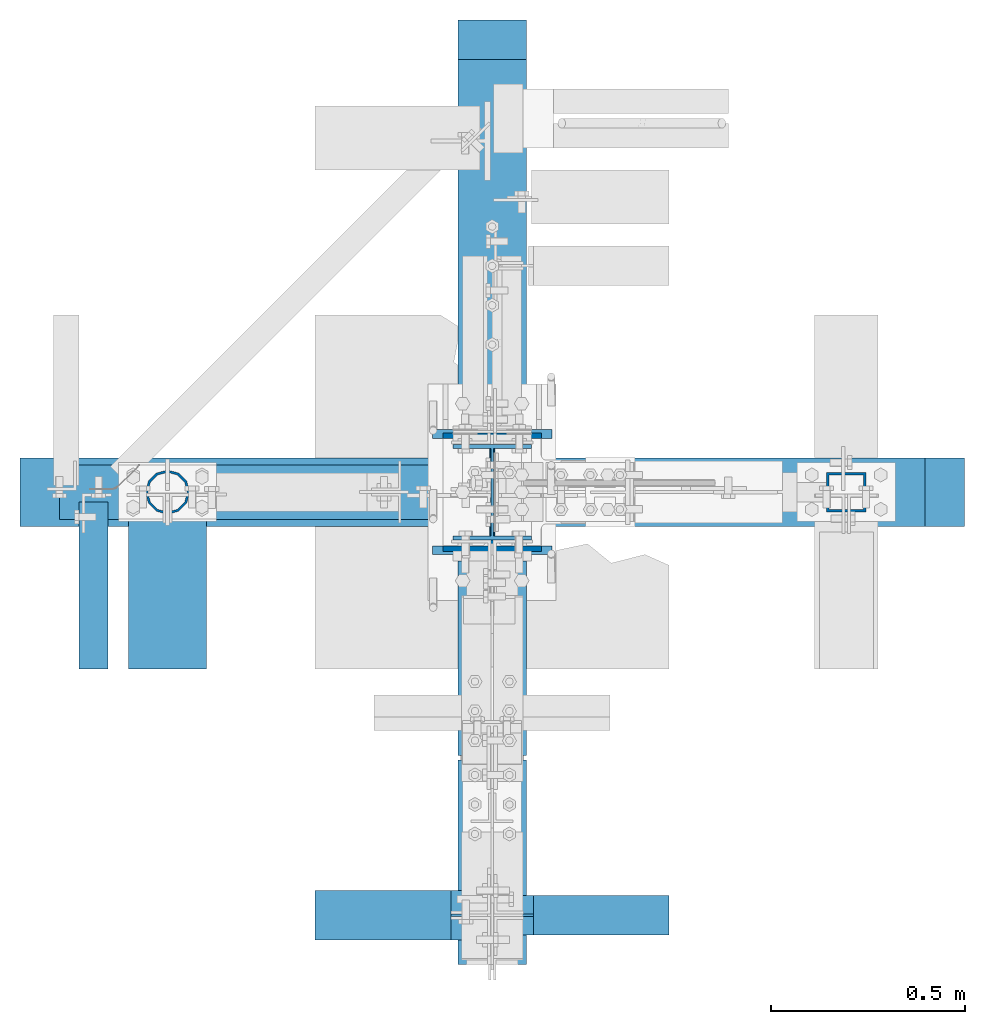
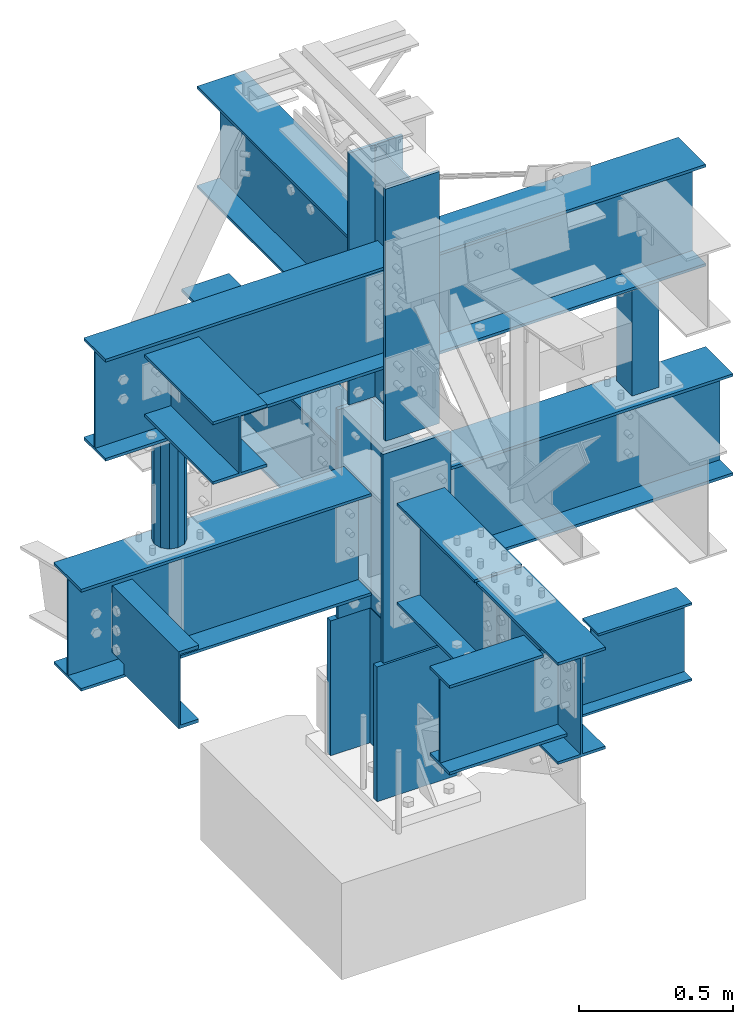
# Not in any storey, part 7 of 8: 12 beams, 5 columns, 17 elements without a shape of their own.
"""IFC2X3 building model written with IfcOpenShell, lengths in inches."""

from ifc_helpers import new_model, entity, si_unit, converted_unit, frame, origin_with_axes, place, context, project, spatial, faceted_brep, source, transform, mapped, material, type_object, type_shapes, element, aggregate, save


model = new_model("IFC2X3")

# Units and contexts
model_context = context("Model", 3, precision=1e-05, world=origin_with_axes())
ifc_project = project(units=[converted_unit("LENGTHUNIT", "INCH", entity("IfcLengthMeasure", 25.4), si_unit("LENGTHUNIT", "METRE", prefix="MILLI"), dimensions=[1, 0, 0, 0, 0, 0, 0]), si_unit("PLANEANGLEUNIT", "RADIAN"), si_unit("MASSUNIT", "GRAM", prefix="KILO"), si_unit("TIMEUNIT", "SECOND"), si_unit("AREAUNIT", "SQUARE_METRE"), si_unit("PRESSUREUNIT", "PASCAL"), si_unit("FORCEUNIT", "NEWTON"), si_unit("THERMODYNAMICTEMPERATUREUNIT", "DEGREE_CELSIUS")], contexts=[model_context])

# Site, building
site_placement = place(None, origin_with_axes())
site = spatial("IfcSite", under=ifc_project, at=site_placement, CompositionType="ELEMENT")
building_placement = place(site_placement, origin_with_axes())
building = spatial("IfcBuilding", under=site, at=building_placement, Name="Building", CompositionType="ELEMENT")

# Assembly, column
assembly_1_placement = place(building_placement, frame((0.0, 0.0, -1.5), z_axis=(0.0, -1.0, 0.0), x_axis=(0.0, 0.0, 1.0)))
assembly_1 = element("IfcElementAssembly", 1, at=assembly_1_placement, inside=building, Name="1-1", PredefinedType="NOTDEFINED")
ifc_material_1 = material()
column_type_1 = type_object("IfcColumnType", Name="W12x96", PredefinedType="COLUMN", material=ifc_material_1)
shared_shape_1 = source(origin_with_axes(), model_context, "Body", "Brep", [
    faceted_brep([(0.0, -6.08, -6.355), (0.0, -6.08, -5.455), (0.0, -0.275, -5.455), (0.0, -0.275, 5.455), (0.0, -6.08, 5.455), (0.0, -6.08, 6.355), (0.0, 6.08, 6.355), (0.0, 6.08, 5.455), (0.0, 0.275, 5.455), (0.0, 0.275, -5.455), (0.0, 6.08, -5.455), (0.0, 6.08, -6.355), (21.0, 6.08, -6.355), (21.0, 6.08, -5.455), (21.0, 0.275, -5.455), (21.0, 0.275, 5.455), (21.0, 6.08, 5.455), (21.0, 6.08, 6.355), (21.0, -6.08, 6.355), (21.0, -6.08, 5.455), (21.0, -0.275, 5.455), (21.0, -0.275, -5.455), (21.0, -6.08, -5.455), (21.0, -6.08, -6.355)], [[[0, 1, 2, 3, 4, 5, 6, 7, 8, 9, 10, 11]], [[12, 13, 14, 15, 16, 17, 18, 19, 20, 21, 22, 23]], [[0, 23, 22, 1]], [[1, 22, 21, 2]], [[2, 21, 20, 3]], [[3, 20, 19, 4]], [[4, 19, 18, 5]], [[5, 18, 17, 6]], [[6, 17, 16, 7]], [[7, 16, 15, 8]], [[8, 15, 14, 9]], [[9, 14, 13, 10]], [[10, 13, 12, 11]], [[11, 12, 23, 0]]]),
])
type_shapes(column_type_1, [shared_shape_1])
column_1_placement = place(assembly_1_placement, frame((1.5, 0.0, 0.0), z_axis=(0.0, 0.0, 1.0), x_axis=(1.0, 0.0, 0.0)))
column_1 = element("IfcColumn", 2, at=column_1_placement, type_object=column_type_1, Name="w1", ObjectType="Column", context=model_context, shape_type="MappedRepresentation", body=[
    mapped(shared_shape_1, transform((0.0, 0.0, 0.0), scale=1.0)),
])
aggregate(assembly_1, [column_1])

assembly_2_placement = place(building_placement, frame((0.0, 0.0, 21.0), z_axis=(0.0, -1.0, 0.0), x_axis=(0.0, 0.0, 1.0)))
assembly_2 = element("IfcElementAssembly", 3, at=assembly_2_placement, inside=building, Name="1-2", PredefinedType="NOTDEFINED")
column_type_2 = type_object("IfcColumnType", Name="W12x53", PredefinedType="COLUMN", material=ifc_material_1)
shared_shape_2 = source(origin_with_axes(), model_context, "Body", "Brep", [
    faceted_brep([(0.0, -4.997, -6.03), (0.0, -4.997, -5.455), (0.0, -0.172, -5.455), (0.0, -0.172, 5.455), (0.0, -4.997, 5.455), (0.0, -4.997, 6.03), (0.0, 4.997, 6.03), (0.0, 4.997, 5.455), (0.0, 0.172, 5.455), (0.0, 0.172, -5.455), (0.0, 4.997, -5.455), (0.0, 4.997, -6.03), (32.5, 4.997, -6.03), (32.5, 4.997, -5.455), (32.5, 0.172, -5.455), (32.5, 0.172, 5.455), (32.5, 4.997, 5.455), (32.5, 4.997, 6.03), (32.5, -4.997, 6.03), (32.5, -4.997, 5.455), (32.5, -0.172, 5.455), (32.5, -0.172, -5.455), (32.5, -4.997, -5.455), (32.5, -4.997, -6.03)], [[[0, 1, 2, 3, 4, 5, 6, 7, 8, 9, 10, 11]], [[12, 13, 14, 15, 16, 17, 18, 19, 20, 21, 22, 23]], [[0, 23, 22, 1]], [[1, 22, 21, 2]], [[2, 21, 20, 3]], [[3, 20, 19, 4]], [[4, 19, 18, 5]], [[5, 18, 17, 6]], [[6, 17, 16, 7]], [[7, 16, 15, 8]], [[8, 15, 14, 9]], [[9, 14, 13, 10]], [[10, 13, 12, 11]], [[11, 12, 23, 0]]]),
])
type_shapes(column_type_2, [shared_shape_2])
column_2_placement = place(assembly_2_placement, origin_with_axes())
column_2 = element("IfcColumn", 4, at=column_2_placement, type_object=column_type_2, Name="w10", ObjectType="Column", context=model_context, shape_type="MappedRepresentation", body=[
    mapped(shared_shape_2, transform((0.0, 0.0, 0.0), scale=1.0)),
])
aggregate(assembly_2, [column_2])

assembly_3_placement = place(building_placement, frame((0.0, 0.0, 54.5), z_axis=(0.0, -1.0, 0.0), x_axis=(0.0, 0.0, 1.0)))
assembly_3 = element("IfcElementAssembly", 5, at=assembly_3_placement, inside=building, Name="1-3", PredefinedType="NOTDEFINED")
column_type_3 = type_object("IfcColumnType", Name="W10x33", PredefinedType="COLUMN", material=ifc_material_1)
shared_shape_3 = source(origin_with_axes(), model_context, "Body", "Brep", [
    faceted_brep([(0.0, -3.98, -4.865), (0.0, -3.98, -4.43), (0.0, -0.145, -4.43), (0.0, -0.145, 4.43), (0.0, -3.98, 4.43), (0.0, -3.98, 4.865), (0.0, 3.98, 4.865), (0.0, 3.98, 4.43), (0.0, 0.145, 4.43), (0.0, 0.145, -4.43), (0.0, 3.98, -4.43), (0.0, 3.98, -4.865), (39.25, 3.98, -4.865), (39.25, 3.98, -4.43), (39.25, 0.145, -4.43), (39.25, 0.145, 4.43), (39.25, 3.98, 4.43), (39.25, 3.98, 4.865), (39.25, -3.98, 4.865), (39.25, -3.98, 4.43), (39.25, -0.145, 4.43), (39.25, -0.145, -4.43), (39.25, -3.98, -4.43), (39.25, -3.98, -4.865)], [[[0, 1, 2, 3, 4, 5, 6, 7, 8, 9, 10, 11]], [[12, 13, 14, 15, 16, 17, 18, 19, 20, 21, 22, 23]], [[0, 23, 22, 1]], [[1, 22, 21, 2]], [[2, 21, 20, 3]], [[3, 20, 19, 4]], [[4, 19, 18, 5]], [[5, 18, 17, 6]], [[6, 17, 16, 7]], [[7, 16, 15, 8]], [[8, 15, 14, 9]], [[9, 14, 13, 10]], [[10, 13, 12, 11]], [[11, 12, 23, 0]]]),
])
type_shapes(column_type_3, [shared_shape_3])
column_3_placement = place(assembly_3_placement, origin_with_axes())
column_3 = element("IfcColumn", 6, at=column_3_placement, type_object=column_type_3, Name="w12", ObjectType="Column", context=model_context, shape_type="MappedRepresentation", body=[
    mapped(shared_shape_3, transform((0.0, 0.0, 0.0), scale=1.0)),
])
aggregate(assembly_3, [column_3])

assembly_4_placement = place(building_placement, frame((36.0, 0.0, 46.0), z_axis=(-1.0, 0.0, 0.0), x_axis=(0.0, 0.0, 1.0)))
assembly_4 = element("IfcElementAssembly", 7, at=assembly_4_placement, inside=building, Name="4-1", PredefinedType="NOTDEFINED")
ifc_material_2 = material()
column_type_4 = type_object("IfcColumnType", Name="HSS4x4x1/4", PredefinedType="COLUMN", material=ifc_material_2)
shared_shape_4 = source(origin_with_axes(), model_context, "Body", "Brep", [
    faceted_brep([(0.0, -2.0, 2.0), (17.125, -2.0, 2.0), (17.125, 2.0, 2.0), (0.0, 2.0, 2.0), (0.0, -2.0, -2.0), (17.125, -2.0, -2.0), (0.0, 2.0, -2.0), (17.125, 2.0, -2.0), (0.0, -1.75, 1.75), (0.0, 1.75, 1.75), (17.125, 1.75, 1.75), (17.125, -1.75, 1.75), (0.0, 1.75, -1.75), (17.125, 1.75, -1.75), (0.0, -1.75, -1.75), (17.125, -1.75, -1.75)], [[[0, 1, 2, 3]], [[4, 5, 1, 0]], [[6, 7, 5, 4]], [[3, 2, 7, 6]], [[8, 9, 10, 11]], [[9, 12, 13, 10]], [[12, 14, 15, 13]], [[14, 8, 11, 15]], [[0, 3, 9, 8]], [[3, 6, 12, 9]], [[6, 4, 14, 12]], [[4, 0, 8, 14]], [[1, 5, 15, 11]], [[2, 1, 11, 10]], [[7, 2, 10, 13]], [[5, 7, 13, 15]]]),
])
type_shapes(column_type_4, [shared_shape_4])
column_4_placement = place(assembly_4_placement, frame((0.5, 0.0, 0.0), z_axis=(0.0, 0.0, 1.0), x_axis=(1.0, 0.0, 0.0)))
column_4 = element("IfcColumn", 8, at=column_4_placement, type_object=column_type_4, Name="ts2", ObjectType="Column", context=model_context, shape_type="MappedRepresentation", body=[
    mapped(shared_shape_4, transform((0.0, 0.0, 0.0), scale=1.0)),
])
aggregate(assembly_4, [column_4])

assembly_5_placement = place(building_placement, frame((-33.0, 0.0, 46.0), z_axis=(-1.0, 0.0, 0.0), x_axis=(0.0, 0.0, 1.0)))
assembly_5 = element("IfcElementAssembly", 9, at=assembly_5_placement, inside=building, Name="4-2", PredefinedType="NOTDEFINED")
ifc_material_3 = material()
column_type_5 = type_object("IfcColumnType", Name="PIPE-4-STD", PredefinedType="COLUMN", material=ifc_material_3)
shared_shape_5 = source(origin_with_axes(), model_context, "Body", "Brep", [
    faceted_brep([(0.0, 0.0, 2.25), (17.125, 0.0, 2.25), (17.125, 1.125, 1.949), (0.0, 1.125, 1.949), (17.125, 1.94856, 1.125), (0.0, 1.94856, 1.125), (17.125, 2.25, 0.0), (0.0, 2.25, 0.0), (17.125, 1.94856, -1.125), (0.0, 1.94856, -1.125), (17.125, 1.125, -1.949), (0.0, 1.125, -1.949), (17.125, -1e-05, -2.25), (0.0, -1e-05, -2.25), (17.125, -1.12501, -1.949), (0.0, -1.12501, -1.949), (17.125, -1.94856, -1.125), (0.0, -1.94856, -1.125), (17.125, -2.25, 0.0), (0.0, -2.25, 0.0), (17.125, -1.94855, 1.125), (0.0, -1.94855, 1.125), (17.125, -1.12499, 1.949), (0.0, -1.12499, 1.949), (17.125, 0.0, 2.013), (0.0, 0.0, 2.013), (0.0, 1.0065, 1.743), (17.125, 1.0065, 1.743), (0.0, 1.74331, 1.006), (17.125, 1.74331, 1.006), (0.0, 2.013, 0.0), (17.125, 2.013, 0.0), (0.0, 1.74331, -1.007), (17.125, 1.74331, -1.007), (0.0, 1.0065, -1.743), (17.125, 1.0065, -1.743), (0.0, 0.0, -2.013), (17.125, 0.0, -2.013), (0.0, -1.0065, -1.743), (17.125, -1.0065, -1.743), (0.0, -1.74331, -1.006), (17.125, -1.74331, -1.006), (0.0, -2.013, 0.0), (17.125, -2.013, 0.0), (0.0, -1.74331, 1.007), (17.125, -1.74331, 1.007), (0.0, -1.00649, 1.743), (17.125, -1.00649, 1.743)], [[[0, 1, 2, 3]], [[3, 2, 4, 5]], [[5, 4, 6, 7]], [[7, 6, 8, 9]], [[9, 8, 10, 11]], [[11, 10, 12, 13]], [[13, 12, 14, 15]], [[15, 14, 16, 17]], [[17, 16, 18, 19]], [[19, 18, 20, 21]], [[21, 20, 22, 23]], [[23, 22, 1, 0]], [[24, 25, 26, 27]], [[0, 3, 26, 25]], [[1, 24, 27, 2]], [[27, 26, 28, 29]], [[3, 5, 28, 26]], [[2, 27, 29, 4]], [[29, 28, 30, 31]], [[5, 7, 30, 28]], [[4, 29, 31, 6]], [[31, 30, 32, 33]], [[7, 9, 32, 30]], [[6, 31, 33, 8]], [[33, 32, 34, 35]], [[9, 11, 34, 32]], [[8, 33, 35, 10]], [[35, 34, 36, 37]], [[11, 13, 36, 34]], [[10, 35, 37, 12]], [[37, 36, 38, 39]], [[13, 15, 38, 36]], [[12, 37, 39, 14]], [[39, 38, 40, 41]], [[15, 17, 40, 38]], [[14, 39, 41, 16]], [[41, 40, 42, 43]], [[17, 19, 42, 40]], [[16, 41, 43, 18]], [[43, 42, 44, 45]], [[19, 21, 44, 42]], [[18, 43, 45, 20]], [[45, 44, 46, 47]], [[21, 23, 46, 44]], [[20, 45, 47, 22]], [[47, 46, 25, 24]], [[23, 0, 25, 46]], [[22, 47, 24, 1]]]),
])
type_shapes(column_type_5, [shared_shape_5])
column_5_placement = place(assembly_5_placement, frame((0.5, 0.0, 0.0), z_axis=(0.0, 0.0, 1.0), x_axis=(1.0, 0.0, 0.0)))
column_5 = element("IfcColumn", 10, at=column_5_placement, type_object=column_type_5, Name="pp1", ObjectType="Column", context=model_context, shape_type="MappedRepresentation", body=[
    mapped(shared_shape_5, transform((0.0, 0.0, 0.0), scale=1.0)),
])
aggregate(assembly_5, [column_5])

# Assembly, beam
assembly_6_placement = place(building_placement, frame((0.0, 0.0, 46.0), z_axis=(0.0, 0.0, 1.0), x_axis=(0.0, 1.0, 0.0)))
assembly_6 = element("IfcElementAssembly", 11, at=assembly_6_placement, inside=building, Name="2-3", PredefinedType="NOTDEFINED")
beam_type_1 = type_object("IfcBeamType", Name="W16x36", PredefinedType="BEAM", material=ifc_material_1)
shared_shape_6 = source(origin_with_axes(), model_context, "Body", "Brep", [
    faceted_brep([(0.0, -3.493, -15.86), (0.0, -3.493, -15.43), (0.0, -0.147, -15.43), (0.0, -0.147, -0.43), (0.0, -3.493, -0.43), (0.0, -3.493, 0.0), (0.0, 3.493, 0.0), (0.0, 3.493, -0.43), (0.0, 0.147, -0.43), (0.0, 0.147, -15.43), (0.0, 3.493, -15.43), (0.0, 3.493, -15.86), (41.75, 3.493, -15.86), (41.75, 3.493, -15.43), (41.75, 0.147, -15.43), (41.75, 0.147, -0.43), (41.75, 3.493, -0.43), (41.75, 3.493, 0.0), (41.75, -3.493, 0.0), (41.75, -3.493, -0.43), (41.75, -0.147, -0.43), (41.75, -0.147, -15.43), (41.75, -3.493, -15.43), (41.75, -3.493, -15.86)], [[[0, 1, 2, 3, 4, 5, 6, 7, 8, 9, 10, 11]], [[12, 13, 14, 15, 16, 17, 18, 19, 20, 21, 22, 23]], [[0, 23, 22, 1]], [[1, 22, 21, 2]], [[2, 21, 20, 3]], [[3, 20, 19, 4]], [[4, 19, 18, 5]], [[5, 18, 17, 6]], [[6, 17, 16, 7]], [[7, 16, 15, 8]], [[8, 15, 14, 9]], [[9, 14, 13, 10]], [[10, 13, 12, 11]], [[11, 12, 23, 0]]]),
])
type_shapes(beam_type_1, [shared_shape_6])
beam_1_placement = place(assembly_6_placement, frame((6.25, 0.0, 0.0), z_axis=(0.0, 0.0, 1.0), x_axis=(1.0, 0.0, 0.0)))
beam_1 = element("IfcBeam", 12, at=beam_1_placement, type_object=beam_type_1, Name="w19", ObjectType="Beam", context=model_context, shape_type="MappedRepresentation", body=[
    mapped(shared_shape_6, transform((0.0, 0.0, 0.0), scale=1.0)),
])
aggregate(assembly_6, [beam_1])

assembly_7_placement = place(building_placement, frame((0.0, 0.0, 46.0), z_axis=(0.0, 0.0, 1.0), x_axis=(-1.0, 0.0, 0.0)))
assembly_7 = element("IfcElementAssembly", 13, at=assembly_7_placement, inside=building, Name="2-4", PredefinedType="NOTDEFINED")
beam_type_2 = type_object("IfcBeamType", Name="W16x36", PredefinedType="BEAM", material=ifc_material_1)
shared_shape_7 = source(origin_with_axes(), model_context, "Body", "Brep", [
    faceted_brep([(0.0, -3.493, -15.86), (0.0, -3.493, -15.43), (0.0, -0.147, -15.43), (0.0, -0.147, -0.43), (0.0, -3.493, -0.43), (0.0, -3.493, 0.0), (0.0, 3.493, 0.0), (0.0, 3.493, -0.43), (0.0, 0.147, -0.43), (0.0, 0.147, -15.43), (0.0, 3.493, -15.43), (0.0, 3.493, -15.86), (42.75, 3.493, -15.86), (42.75, 3.493, -15.43), (42.75, 0.147, -15.43), (42.75, 0.147, -0.43), (42.75, 3.493, -0.43), (42.75, 3.493, 0.0), (42.75, -3.493, 0.0), (42.75, -3.493, -0.43), (42.75, -0.147, -0.43), (42.75, -0.147, -15.43), (42.75, -3.493, -15.43), (42.75, -3.493, -15.86)], [[[0, 1, 2, 3, 4, 5, 6, 7, 8, 9, 10, 11]], [[12, 13, 14, 15, 16, 17, 18, 19, 20, 21, 22, 23]], [[0, 23, 22, 1]], [[1, 22, 21, 2]], [[2, 21, 20, 3]], [[3, 20, 19, 4]], [[4, 19, 18, 5]], [[5, 18, 17, 6]], [[6, 17, 16, 7]], [[7, 16, 15, 8]], [[8, 15, 14, 9]], [[9, 14, 13, 10]], [[10, 13, 12, 11]], [[11, 12, 23, 0]]]),
])
type_shapes(beam_type_2, [shared_shape_7])
beam_2_placement = place(assembly_7_placement, frame((5.25, 0.0, 0.0), z_axis=(0.0, 0.0, 1.0), x_axis=(1.0, 0.0, 0.0)))
beam_2 = element("IfcBeam", 14, at=beam_2_placement, type_object=beam_type_2, Name="w11", ObjectType="Beam", context=model_context, shape_type="MappedRepresentation", body=[
    mapped(shared_shape_7, transform((0.0, 0.0, 0.0), scale=1.0)),
])
aggregate(assembly_7, [beam_2])

assembly_8_placement = place(building_placement, frame((0.0, 0.0, 46.0), z_axis=(0.0, 0.0, 1.0), x_axis=(1.0, 0.0, 0.0)))
assembly_8 = element("IfcElementAssembly", 15, at=assembly_8_placement, inside=building, Name="2-5", PredefinedType="NOTDEFINED")
beam_type_3 = type_object("IfcBeamType", Name="W16x36", PredefinedType="BEAM", material=ifc_material_1)
shared_shape_8 = source(origin_with_axes(), model_context, "Body", "Brep", [
    faceted_brep([(0.0, -3.493, -15.86), (0.0, -3.493, -15.43), (0.0, -0.147, -15.43), (0.0, -0.147, -0.43), (0.0, -3.493, -0.43), (0.0, -3.493, 0.0), (0.0, 3.493, 0.0), (0.0, 3.493, -0.43), (0.0, 0.147, -0.43), (0.0, 0.147, -15.43), (0.0, 3.493, -15.43), (0.0, 3.493, -15.86), (42.5, 3.493, -15.86), (42.5, 3.493, -15.43), (42.5, 0.147, -15.43), (42.5, 0.147, -0.43), (42.5, 3.493, -0.43), (42.5, 3.493, 0.0), (42.5, -3.493, 0.0), (42.5, -3.493, -0.43), (42.5, -0.147, -0.43), (42.5, -0.147, -15.43), (42.5, -3.493, -15.43), (42.5, -3.493, -15.86)], [[[0, 1, 2, 3, 4, 5, 6, 7, 8, 9, 10, 11]], [[12, 13, 14, 15, 16, 17, 18, 19, 20, 21, 22, 23]], [[0, 23, 22, 1]], [[1, 22, 21, 2]], [[2, 21, 20, 3]], [[3, 20, 19, 4]], [[4, 19, 18, 5]], [[5, 18, 17, 6]], [[6, 17, 16, 7]], [[7, 16, 15, 8]], [[8, 15, 14, 9]], [[9, 14, 13, 10]], [[10, 13, 12, 11]], [[11, 12, 23, 0]]]),
])
type_shapes(beam_type_3, [shared_shape_8])
beam_3_placement = place(assembly_8_placement, frame((5.5, 0.0, 0.0), z_axis=(0.0, 0.0, 1.0), x_axis=(1.0, 0.0, 0.0)))
beam_3 = element("IfcBeam", 16, at=beam_3_placement, type_object=beam_type_3, Name="w22", ObjectType="Beam", context=model_context, shape_type="MappedRepresentation", body=[
    mapped(shared_shape_8, transform((0.0, 0.0, 0.0), scale=1.0)),
])
aggregate(assembly_8, [beam_3])

assembly_9_placement = place(building_placement, frame((0.0, 0.0, 46.0), z_axis=(0.0, 0.0, 1.0), x_axis=(0.0, -1.0, 0.0)))
assembly_9 = element("IfcElementAssembly", 17, at=assembly_9_placement, inside=building, Name="2-1", PredefinedType="NOTDEFINED")
beam_type_4 = type_object("IfcBeamType", Name="W16x36", PredefinedType="BEAM", material=ifc_material_1)
shared_shape_9 = source(origin_with_axes(), model_context, "Body", "Brep", [
    faceted_brep([(0.0, -3.493, -15.86), (0.0, -3.493, -15.43), (0.0, -0.147, -15.43), (0.0, -0.147, -0.43), (0.0, -3.493, -0.43), (0.0, -3.493, 0.0), (0.0, 3.493, 0.0), (0.0, 3.493, -0.43), (0.0, 0.147, -0.43), (0.0, 0.147, -15.43), (0.0, 3.493, -15.43), (0.0, 3.493, -15.86), (19.75, 3.493, -15.86), (19.75, 3.493, -15.43), (19.75, 0.147, -15.43), (19.75, 0.147, -0.43), (19.75, 3.493, -0.43), (19.75, 3.493, 0.0), (19.75, -3.493, 0.0), (19.75, -3.493, -0.43), (19.75, -0.147, -0.43), (19.75, -0.147, -15.43), (19.75, -3.493, -15.43), (19.75, -3.493, -15.86)], [[[0, 1, 2, 3, 4, 5, 6, 7, 8, 9, 10, 11]], [[12, 13, 14, 15, 16, 17, 18, 19, 20, 21, 22, 23]], [[0, 23, 22, 1]], [[1, 22, 21, 2]], [[2, 21, 20, 3]], [[3, 20, 19, 4]], [[4, 19, 18, 5]], [[5, 18, 17, 6]], [[6, 17, 16, 7]], [[7, 16, 15, 8]], [[8, 15, 14, 9]], [[9, 14, 13, 10]], [[10, 13, 12, 11]], [[11, 12, 23, 0]]]),
])
type_shapes(beam_type_4, [shared_shape_9])
beam_4_placement = place(assembly_9_placement, frame((7.0, 0.0, 0.0), z_axis=(0.0, 0.0, 1.0), x_axis=(1.0, 0.0, 0.0)))
beam_4 = element("IfcBeam", 18, at=beam_4_placement, type_object=beam_type_4, Name="w5", ObjectType="Beam", context=model_context, shape_type="MappedRepresentation", body=[
    mapped(shared_shape_9, transform((0.0, 0.0, 0.0), scale=1.0)),
])
aggregate(assembly_9, [beam_4])

assembly_10_placement = place(building_placement, frame((0.0, -27.0, 46.0), z_axis=(0.0, 0.0, 1.0), x_axis=(0.0, -1.0, 0.0)))
assembly_10 = element("IfcElementAssembly", 19, at=assembly_10_placement, inside=building, Name="2-2", PredefinedType="NOTDEFINED")
beam_type_5 = type_object("IfcBeamType", Name="W16x36", PredefinedType="BEAM", material=ifc_material_1)
shared_shape_10 = source(origin_with_axes(), model_context, "Body", "Brep", [
    faceted_brep([(0.0, -3.493, -15.86), (0.0, -3.493, -15.43), (0.0, -0.147, -15.43), (0.0, -0.147, -0.43), (0.0, -3.493, -0.43), (0.0, -3.493, 0.0), (0.0, 3.493, 0.0), (0.0, 3.493, -0.43), (0.0, 0.147, -0.43), (0.0, 0.147, -15.43), (0.0, 3.493, -15.43), (0.0, 3.493, -15.86), (20.75, 3.493, -15.86), (20.75, 3.493, -15.43), (20.75, 0.147, -15.43), (20.75, 0.147, -0.43), (20.75, 3.493, -0.43), (20.75, 3.493, 0.0), (20.75, -3.493, 0.0), (20.75, -3.493, -0.43), (20.75, -0.147, -0.43), (20.75, -0.147, -15.43), (20.75, -3.493, -15.43), (20.75, -3.493, -15.86)], [[[0, 1, 2, 3, 4, 5, 6, 7, 8, 9, 10, 11]], [[12, 13, 14, 15, 16, 17, 18, 19, 20, 21, 22, 23]], [[0, 23, 22, 1]], [[1, 22, 21, 2]], [[2, 21, 20, 3]], [[3, 20, 19, 4]], [[4, 19, 18, 5]], [[5, 18, 17, 6]], [[6, 17, 16, 7]], [[7, 16, 15, 8]], [[8, 15, 14, 9]], [[9, 14, 13, 10]], [[10, 13, 12, 11]], [[11, 12, 23, 0]]]),
])
type_shapes(beam_type_5, [shared_shape_10])
beam_5_placement = place(assembly_10_placement, frame((0.25, 0.0, 0.0), z_axis=(0.0, 0.0, 1.0), x_axis=(1.0, 0.0, 0.0)))
beam_5 = element("IfcBeam", 20, at=beam_5_placement, type_object=beam_type_5, Name="w21", ObjectType="Beam", context=model_context, shape_type="MappedRepresentation", body=[
    mapped(shared_shape_10, transform((0.0, 0.0, 0.0), scale=1.0)),
])
aggregate(assembly_10, [beam_5])

assembly_11_placement = place(building_placement, frame((-42.0, 0.0, 43.0), z_axis=(0.0, 0.0, 1.0), x_axis=(0.0, -1.0, 0.0)))
assembly_11 = element("IfcElementAssembly", 21, at=assembly_11_placement, inside=building, Name="3-7", PredefinedType="NOTDEFINED")
ifc_material_4 = material()
beam_type_6 = type_object("IfcBeamType", Name="C12x20.7", PredefinedType="BEAM", material=ifc_material_4)
shared_shape_11 = source(origin_with_axes(), model_context, "Body", "Brep", [
    faceted_brep([(0.0, -2.942, 0.0), (0.0, 0.0, 0.0), (0.0, 0.0, -0.501), (0.0, -2.942, -0.501), (17.0, 0.0, 0.0), (17.0, 0.0, -0.501), (17.0, -2.942, 0.0), (17.0, -2.942, -0.501), (0.0, -0.282, -0.501), (0.0, 0.0, -0.501), (0.0, 0.0, -5.45), (0.0, -0.282, -5.45), (0.0, 0.0, -6.55), (0.0, -0.282, -6.55), (0.0, 0.0, -11.499), (0.0, -0.282, -11.499), (8.33, 0.0, -11.499), (8.33, -0.282, -11.499), (14.0, 0.0, -11.499), (14.0, -0.282, -11.499), (14.0, 0.0, -10.374), (14.0, -0.282, -10.374), (17.0, 0.0, -10.374), (17.0, -0.282, -10.374), (17.0, 0.0, -5.45), (17.0, -0.282, -5.45), (17.0, 0.0, -0.501), (17.0, -0.282, -0.501), (8.67, 0.0, -0.501), (8.67, -0.282, -0.501), (8.33, 0.0, -0.501), (8.33, -0.282, -0.501), (0.0, -2.942, -11.499), (0.0, 0.0, -11.499), (0.0, 0.0, -12.0), (0.0, -2.942, -12.0), (14.0, 0.0, -11.499), (14.0, 0.0, -12.0), (14.0, -2.942, -11.499), (14.0, -2.942, -12.0)], [[[0, 1, 2, 3]], [[1, 4, 5, 2]], [[4, 6, 7, 5]], [[6, 0, 3, 7]], [[6, 4, 1, 0]], [[3, 2, 5, 7]], [[8, 9, 10, 11]], [[11, 10, 12, 13]], [[13, 12, 14, 15]], [[15, 14, 16, 17]], [[17, 16, 18, 19]], [[19, 18, 20, 21]], [[21, 20, 22, 23]], [[23, 22, 24, 25]], [[25, 24, 26, 27]], [[27, 26, 28, 29]], [[29, 28, 30, 31]], [[8, 31, 30, 9]], [[8, 11, 13, 15, 17, 19, 21, 23, 25, 27, 29, 31]], [[26, 24, 22, 20, 18, 16, 14, 12, 10, 9, 30, 28]], [[32, 33, 34, 35]], [[33, 36, 37, 34]], [[36, 38, 39, 37]], [[38, 32, 35, 39]], [[38, 36, 33, 32]], [[35, 34, 37, 39]]]),
])
type_shapes(beam_type_6, [shared_shape_11])
beam_6_placement = place(assembly_11_placement, frame((18.0, 0.0, 0.0), z_axis=(0.0, 0.0, 1.0), x_axis=(-1.0, 0.0, 0.0)))
beam_6 = element("IfcBeam", 22, at=beam_6_placement, type_object=beam_type_6, Name="c6", ObjectType="Beam", context=model_context, shape_type="MappedRepresentation", body=[
    mapped(shared_shape_11, transform((0.0, 0.0, 0.0), scale=1.0)),
])
aggregate(assembly_11, [beam_6])

assembly_12_placement = place(building_placement, frame((0.0, -43.0, 46.0), z_axis=(0.0, 0.0, 1.0), x_axis=(1.0, 0.0, 0.0)))
assembly_12 = element("IfcElementAssembly", 23, at=assembly_12_placement, inside=building, Name="3-6", PredefinedType="NOTDEFINED")
beam_type_7 = type_object("IfcBeamType", Name="W12x19", PredefinedType="BEAM", material=ifc_material_1)
shared_shape_12 = source(origin_with_axes(), model_context, "Body", "Brep", [
    faceted_brep([(3.5, -2.002, 0.0), (3.5, 2.002, 0.0), (3.5, 2.002, -0.35), (3.5, -2.002, -0.35), (17.3125, 2.002, 0.0), (17.3125, 2.002, -0.35), (17.3125, -2.002, 0.0), (17.3125, -2.002, -0.35), (3.5, -0.117, -1.125), (3.5, 0.117, -1.125), (0.0, 0.117, -1.125), (0.0, -0.117, -1.125), (0.0, 0.117, -6.653), (0.0, -0.117, -6.653), (0.0, 0.117, -11.81), (0.0, -0.117, -11.81), (8.483, 0.117, -11.81), (8.483, -0.117, -11.81), (8.829, 0.117, -11.81), (8.829, -0.117, -11.81), (17.3125, 0.117, -11.81), (17.3125, -0.117, -11.81), (17.3125, 0.117, -6.653), (17.3125, -0.117, -6.653), (17.3125, 0.117, -5.507), (17.3125, -0.117, -5.507), (17.3125, 0.117, -0.35), (17.3125, -0.117, -0.35), (8.829, 0.117, -0.35), (8.829, -0.117, -0.35), (3.5, 0.117, -0.35), (3.5, -0.117, -0.35), (0.0, -2.002, -11.81), (0.0, 2.002, -11.81), (0.0, 2.002, -12.16), (0.0, -2.002, -12.16), (17.3125, 2.002, -11.81), (17.3125, 2.002, -12.16), (17.3125, -2.002, -11.81), (17.3125, -2.002, -12.16)], [[[0, 1, 2, 3]], [[1, 4, 5, 2]], [[4, 6, 7, 5]], [[6, 0, 3, 7]], [[6, 4, 1, 0]], [[3, 2, 5, 7]], [[8, 9, 10, 11]], [[11, 10, 12, 13]], [[13, 12, 14, 15]], [[15, 14, 16, 17]], [[17, 16, 18, 19]], [[19, 18, 20, 21]], [[21, 20, 22, 23]], [[23, 22, 24, 25]], [[25, 24, 26, 27]], [[27, 26, 28, 29]], [[29, 28, 30, 31]], [[8, 31, 30, 9]], [[8, 11, 13, 15, 17, 19, 21, 23, 25, 27, 29, 31]], [[26, 24, 22, 20, 18, 16, 14, 12, 10, 9, 30, 28]], [[32, 33, 34, 35]], [[33, 36, 37, 34]], [[36, 38, 39, 37]], [[38, 32, 35, 39]], [[38, 36, 33, 32]], [[35, 34, 37, 39]]]),
])
type_shapes(beam_type_7, [shared_shape_12])
beam_7_placement = place(assembly_12_placement, frame((0.6875, 0.0, 0.0), z_axis=(0.0, 0.0, 1.0), x_axis=(1.0, 0.0, 0.0)))
beam_7 = element("IfcBeam", 24, at=beam_7_placement, type_object=beam_type_7, Name="w15", ObjectType="Beam", context=model_context, shape_type="MappedRepresentation", body=[
    mapped(shared_shape_12, transform((0.0, 0.0, 0.0), scale=1.0)),
])
aggregate(assembly_12, [beam_7])

assembly_13_placement = place(building_placement, frame((0.0, -43.0, 46.0), z_axis=(0.0, 0.0, 1.0), x_axis=(-1.0, 0.0, 0.0)))
assembly_13 = element("IfcElementAssembly", 25, at=assembly_13_placement, inside=building, Name="3-5", PredefinedType="NOTDEFINED")
beam_type_8 = type_object("IfcBeamType", Name="W14x26", PredefinedType="BEAM", material=ifc_material_1)
shared_shape_13 = source(origin_with_axes(), model_context, "Body", "Brep", [
    faceted_brep([(3.5, -2.513, 0.0), (3.5, 2.513, 0.0), (3.5, 2.513, -0.42), (3.5, -2.513, -0.42), (17.3125, 2.513, 0.0), (17.3125, 2.513, -0.42), (17.3125, -2.513, 0.0), (17.3125, -2.513, -0.42), (3.5, -0.128, -1.125), (3.5, 0.128, -1.125), (0.0, 0.128, -1.125), (0.0, -0.128, -1.125), (0.0, 0.128, -7.609), (0.0, -0.128, -7.609), (0.0, 0.128, -13.49), (0.0, -0.128, -13.49), (8.483, 0.128, -13.49), (8.483, -0.128, -13.49), (8.829, 0.128, -13.49), (8.829, -0.128, -13.49), (17.3125, 0.128, -13.49), (17.3125, -0.128, -13.49), (17.3125, 0.128, -7.609), (17.3125, -0.128, -7.609), (17.3125, 0.128, -6.301), (17.3125, -0.128, -6.301), (17.3125, 0.128, -0.42), (17.3125, -0.128, -0.42), (8.829, 0.128, -0.42), (8.829, -0.128, -0.42), (3.5, 0.128, -0.42), (3.5, -0.128, -0.42), (0.0, -2.513, -13.49), (0.0, 2.513, -13.49), (0.0, 2.513, -13.91), (0.0, -2.513, -13.91), (17.3125, 2.513, -13.49), (17.3125, 2.513, -13.91), (17.3125, -2.513, -13.49), (17.3125, -2.513, -13.91)], [[[0, 1, 2, 3]], [[1, 4, 5, 2]], [[4, 6, 7, 5]], [[6, 0, 3, 7]], [[6, 4, 1, 0]], [[3, 2, 5, 7]], [[8, 9, 10, 11]], [[11, 10, 12, 13]], [[13, 12, 14, 15]], [[15, 14, 16, 17]], [[17, 16, 18, 19]], [[19, 18, 20, 21]], [[21, 20, 22, 23]], [[23, 22, 24, 25]], [[25, 24, 26, 27]], [[27, 26, 28, 29]], [[29, 28, 30, 31]], [[8, 31, 30, 9]], [[8, 11, 13, 15, 17, 19, 21, 23, 25, 27, 29, 31]], [[26, 24, 22, 20, 18, 16, 14, 12, 10, 9, 30, 28]], [[32, 33, 34, 35]], [[33, 36, 37, 34]], [[36, 38, 39, 37]], [[38, 32, 35, 39]], [[38, 36, 33, 32]], [[35, 34, 37, 39]]]),
])
type_shapes(beam_type_8, [shared_shape_13])
beam_8_placement = place(assembly_13_placement, frame((0.6875, 0.0, 0.0), z_axis=(0.0, 0.0, 1.0), x_axis=(1.0, 0.0, 0.0)))
beam_8 = element("IfcBeam", 26, at=beam_8_placement, type_object=beam_type_8, Name="w6", ObjectType="Beam", context=model_context, shape_type="MappedRepresentation", body=[
    mapped(shared_shape_13, transform((0.0, 0.0, 0.0), scale=1.0)),
])
aggregate(assembly_13, [beam_8])

assembly_14_placement = place(building_placement, frame((0.0, 0.0, 80.0), z_axis=(0.0, 0.0, 1.0), x_axis=(-1.0, 0.0, 0.0)))
assembly_14 = element("IfcElementAssembly", 27, at=assembly_14_placement, inside=building, Name="2-7", PredefinedType="NOTDEFINED")
beam_type_9 = type_object("IfcBeamType", Name="W16x31", PredefinedType="BEAM", material=ifc_material_1)
shared_shape_14 = source(origin_with_axes(), model_context, "Body", "Brep", [
    faceted_brep([(0.0, -2.763, -15.88), (0.0, -2.763, -15.44), (0.0, -0.138, -15.44), (0.0, -0.138, -0.44), (0.0, -2.763, -0.44), (0.0, -2.763, 0.0), (0.0, 2.763, 0.0), (0.0, 2.763, -0.44), (0.0, 0.138, -0.44), (0.0, 0.138, -15.44), (0.0, 2.763, -15.44), (0.0, 2.763, -15.88), (43.3125, 2.763, -15.88), (43.3125, 2.763, -15.44), (43.3125, 0.138, -15.44), (43.3125, 0.138, -0.44), (43.3125, 2.763, -0.44), (43.3125, 2.763, 0.0), (43.3125, -2.763, 0.0), (43.3125, -2.763, -0.44), (43.3125, -0.138, -0.44), (43.3125, -0.138, -15.44), (43.3125, -2.763, -15.44), (43.3125, -2.763, -15.88)], [[[0, 1, 2, 3, 4, 5, 6, 7, 8, 9, 10, 11]], [[12, 13, 14, 15, 16, 17, 18, 19, 20, 21, 22, 23]], [[0, 23, 22, 1]], [[1, 22, 21, 2]], [[2, 21, 20, 3]], [[3, 20, 19, 4]], [[4, 19, 18, 5]], [[5, 18, 17, 6]], [[6, 17, 16, 7]], [[7, 16, 15, 8]], [[8, 15, 14, 9]], [[9, 14, 13, 10]], [[10, 13, 12, 11]], [[11, 12, 23, 0]]]),
])
type_shapes(beam_type_9, [shared_shape_14])
beam_9_placement = place(assembly_14_placement, frame((0.6875, 0.0, 0.0), z_axis=(0.0, 0.0, 1.0), x_axis=(1.0, 0.0, 0.0)))
beam_9 = element("IfcBeam", 28, at=beam_9_placement, type_object=beam_type_9, Name="w20", ObjectType="Beam", context=model_context, shape_type="MappedRepresentation", body=[
    mapped(shared_shape_14, transform((0.0, 0.0, 0.0), scale=1.0)),
])
aggregate(assembly_14, [beam_9])

assembly_15_placement = place(building_placement, frame((0.0, 0.0, 80.0), z_axis=(0.0, 0.0, 1.0), x_axis=(0.0, 1.0, 0.0)))
assembly_15 = element("IfcElementAssembly", 29, at=assembly_15_placement, inside=building, Name="2-6", PredefinedType="NOTDEFINED")
beam_type_10 = type_object("IfcBeamType", Name="W16x36", PredefinedType="BEAM", material=ifc_material_1)
shared_shape_15 = source(origin_with_axes(), model_context, "Body", "Brep", [
    faceted_brep([(0.0, -3.493, -15.86), (0.0, -3.493, -15.43), (0.0, -0.147, -15.43), (0.0, -0.147, -0.43), (0.0, -3.493, -0.43), (0.0, -3.493, 0.0), (0.0, 3.493, 0.0), (0.0, 3.493, -0.43), (0.0, 0.147, -0.43), (0.0, 0.147, -15.43), (0.0, 3.493, -15.43), (0.0, 3.493, -15.86), (38.625, 3.493, -15.86), (38.625, 3.493, -15.43), (38.625, 0.147, -15.43), (38.625, 0.147, -0.43), (38.625, 3.493, -0.43), (38.625, 3.493, 0.0), (38.625, -3.493, 0.0), (38.625, -3.493, -0.43), (38.625, -0.147, -0.43), (38.625, -0.147, -15.43), (38.625, -3.493, -15.43), (38.625, -3.493, -15.86)], [[[0, 1, 2, 3, 4, 5, 6, 7, 8, 9, 10, 11]], [[12, 13, 14, 15, 16, 17, 18, 19, 20, 21, 22, 23]], [[0, 23, 22, 1]], [[1, 22, 21, 2]], [[2, 21, 20, 3]], [[3, 20, 19, 4]], [[4, 19, 18, 5]], [[5, 18, 17, 6]], [[6, 17, 16, 7]], [[7, 16, 15, 8]], [[8, 15, 14, 9]], [[9, 14, 13, 10]], [[10, 13, 12, 11]], [[11, 12, 23, 0]]]),
])
type_shapes(beam_type_10, [shared_shape_15])
beam_10_placement = place(assembly_15_placement, frame((5.375, 0.0, 0.0), z_axis=(0.0, 0.0, 1.0), x_axis=(1.0, 0.0, 0.0)))
beam_10 = element("IfcBeam", 30, at=beam_10_placement, type_object=beam_type_10, Name="w7", ObjectType="Beam", context=model_context, shape_type="MappedRepresentation", body=[
    mapped(shared_shape_15, transform((0.0, 0.0, 0.0), scale=1.0)),
])
aggregate(assembly_15, [beam_10])

assembly_16_placement = place(building_placement, frame((0.0, 0.0, 80.0), z_axis=(0.0, 0.0, 1.0), x_axis=(1.0, 0.0, 0.0)))
assembly_16 = element("IfcElementAssembly", 31, at=assembly_16_placement, inside=building, Name="2-8", PredefinedType="NOTDEFINED")
beam_type_11 = type_object("IfcBeamType", Name="W16x36", PredefinedType="BEAM", material=ifc_material_1)
shared_shape_16 = source(origin_with_axes(), model_context, "Body", "Brep", [
    faceted_brep([(0.0, -3.493, -15.86), (0.0, -3.493, -15.43), (0.0, -0.147, -15.43), (0.0, -0.147, -0.43), (0.0, -3.493, -0.43), (0.0, -3.493, 0.0), (0.0, 3.493, 0.0), (0.0, 3.493, -0.43), (0.0, 0.147, -0.43), (0.0, 0.147, -15.43), (0.0, 3.493, -15.43), (0.0, 3.493, -15.86), (43.0, 3.493, -15.86), (43.0, 3.493, -15.43), (43.0, 0.147, -15.43), (43.0, 0.147, -0.43), (43.0, 3.493, -0.43), (43.0, 3.493, 0.0), (43.0, -3.493, 0.0), (43.0, -3.493, -0.43), (43.0, -0.147, -0.43), (43.0, -0.147, -15.43), (43.0, -3.493, -15.43), (43.0, -3.493, -15.86)], [[[0, 1, 2, 3, 4, 5, 6, 7, 8, 9, 10, 11]], [[12, 13, 14, 15, 16, 17, 18, 19, 20, 21, 22, 23]], [[0, 23, 22, 1]], [[1, 22, 21, 2]], [[2, 21, 20, 3]], [[3, 20, 19, 4]], [[4, 19, 18, 5]], [[5, 18, 17, 6]], [[6, 17, 16, 7]], [[7, 16, 15, 8]], [[8, 15, 14, 9]], [[9, 14, 13, 10]], [[10, 13, 12, 11]], [[11, 12, 23, 0]]]),
])
type_shapes(beam_type_11, [shared_shape_16])
beam_11_placement = place(assembly_16_placement, frame((1.0, 0.0, 0.0), z_axis=(0.0, 0.0, 1.0), x_axis=(1.0, 0.0, 0.0)))
beam_11 = element("IfcBeam", 32, at=beam_11_placement, type_object=beam_type_11, Name="w14", ObjectType="Beam", context=model_context, shape_type="MappedRepresentation", body=[
    mapped(shared_shape_16, transform((0.0, 0.0, 0.0), scale=1.0)),
])
aggregate(assembly_16, [beam_11])

assembly_17_placement = place(building_placement, frame((-33.0, 0.0, 77.0), z_axis=(0.0, 0.0, 1.0), x_axis=(0.0, -1.0, 0.0)))
assembly_17 = element("IfcElementAssembly", 33, at=assembly_17_placement, inside=building, Name="3-10", PredefinedType="NOTDEFINED")
beam_type_12 = type_object("IfcBeamType", Name="W10x33", PredefinedType="BEAM", material=ifc_material_1)
shared_shape_17 = source(origin_with_axes(), model_context, "Body", "Brep", [
    faceted_brep([(0.0, -3.98, -9.73), (0.0, -3.98, -9.295), (0.0, -0.145, -9.295), (0.0, -0.145, -0.435), (0.0, -3.98, -0.435), (0.0, -3.98, 0.0), (0.0, 3.98, 0.0), (0.0, 3.98, -0.435), (0.0, 0.145, -0.435), (0.0, 0.145, -9.295), (0.0, 3.98, -9.295), (0.0, 3.98, -9.73), (17.375, 3.98, -9.73), (17.375, 3.98, -9.295), (17.375, 0.145, -9.295), (17.375, 0.145, -0.435), (17.375, 3.98, -0.435), (17.375, 3.98, 0.0), (17.375, -3.98, 0.0), (17.375, -3.98, -0.435), (17.375, -0.145, -0.435), (17.375, -0.145, -9.295), (17.375, -3.98, -9.295), (17.375, -3.98, -9.73)], [[[0, 1, 2, 3, 4, 5, 6, 7, 8, 9, 10, 11]], [[12, 13, 14, 15, 16, 17, 18, 19, 20, 21, 22, 23]], [[0, 23, 22, 1]], [[1, 22, 21, 2]], [[2, 21, 20, 3]], [[3, 20, 19, 4]], [[4, 19, 18, 5]], [[5, 18, 17, 6]], [[6, 17, 16, 7]], [[7, 16, 15, 8]], [[8, 15, 14, 9]], [[9, 14, 13, 10]], [[10, 13, 12, 11]], [[11, 12, 23, 0]]]),
])
type_shapes(beam_type_12, [shared_shape_17])
beam_12_placement = place(assembly_17_placement, frame((0.625, 0.0, 0.0), z_axis=(0.0, 0.0, 1.0), x_axis=(1.0, 0.0, 0.0)))
beam_12 = element("IfcBeam", 34, at=beam_12_placement, type_object=beam_type_12, Name="w9", ObjectType="Beam", context=model_context, shape_type="MappedRepresentation", body=[
    mapped(shared_shape_17, transform((0.0, 0.0, 0.0), scale=1.0)),
])
aggregate(assembly_17, [beam_12])

save(model, "model.ifc")
